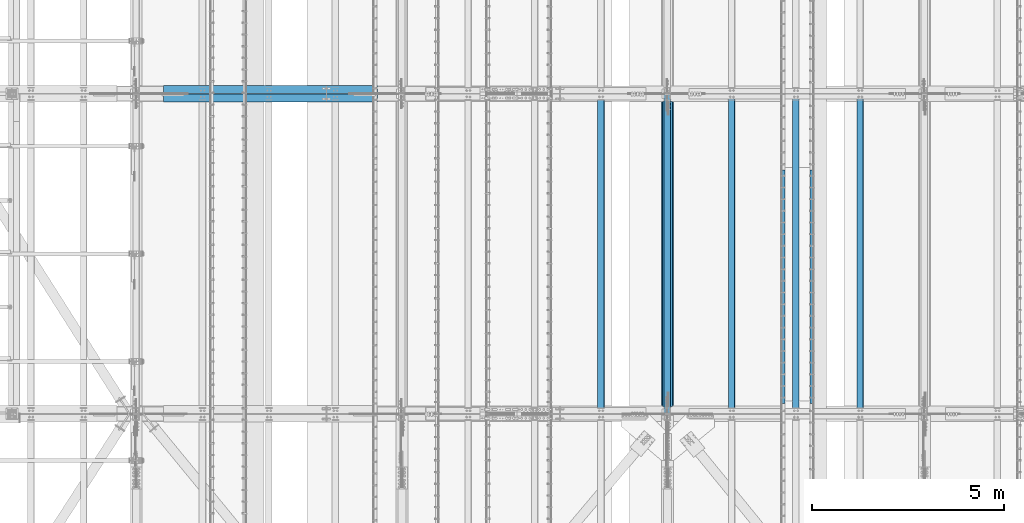
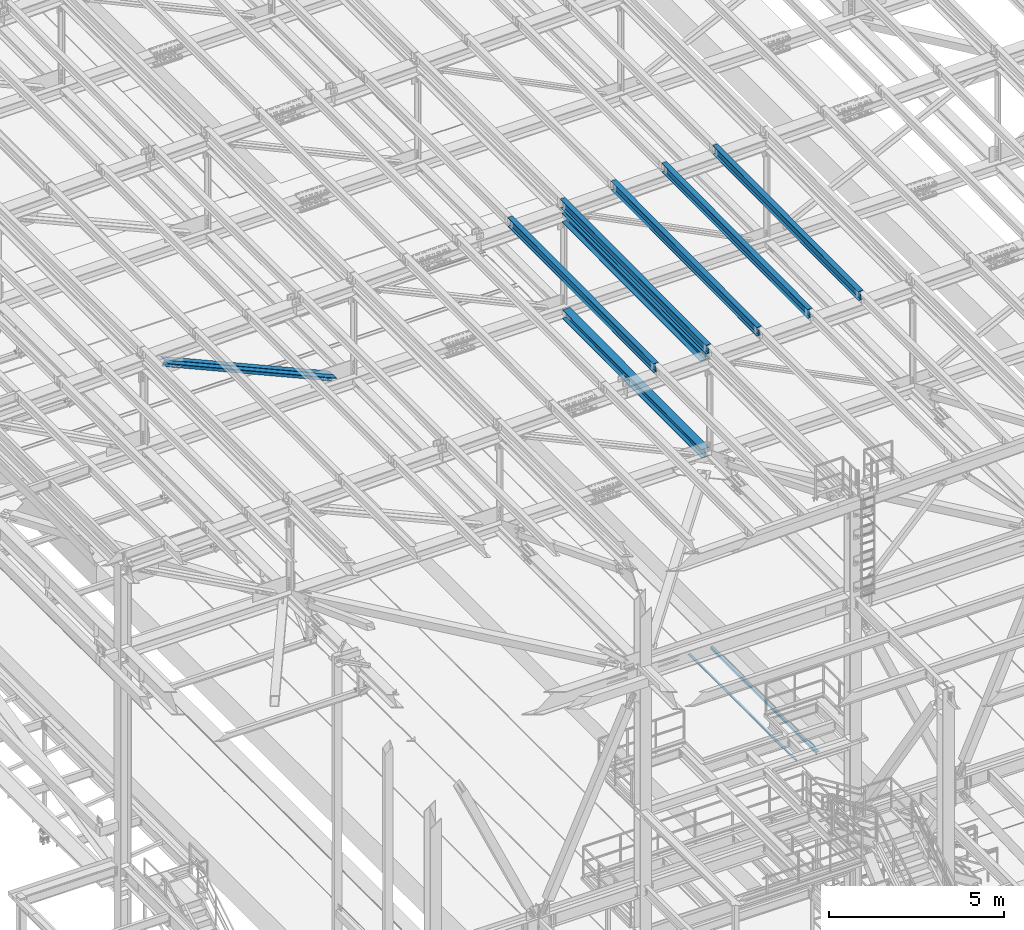
# One storey, part 1826 of 3843: 9 beams, 2 members, 11 elements without a shape of their own.
"""IFC2X3 building model written with IfcOpenShell, lengths in millimetres."""

from ifc_helpers import new_model, si_unit, frame, origin_with_axes, place, context, subcontext, project, spatial, faceted_brep, material, type_object, element, aggregate, save


model = new_model("IFC2X3")

# Units and contexts
model_context = context("Model", 3, precision=1e-05, world=origin_with_axes())
body_context = subcontext(model_context, "Body", "Model", "MODEL_VIEW")
ifc_project = project(units=[si_unit("LENGTHUNIT", "METRE", prefix="MILLI"), si_unit("AREAUNIT", "SQUARE_METRE"), si_unit("VOLUMEUNIT", "CUBIC_METRE"), si_unit("MASSUNIT", "GRAM", prefix="KILO"), si_unit("TIMEUNIT", "SECOND"), si_unit("PLANEANGLEUNIT", "RADIAN"), si_unit("SOLIDANGLEUNIT", "STERADIAN"), si_unit("THERMODYNAMICTEMPERATUREUNIT", "DEGREE_CELSIUS"), si_unit("LUMINOUSINTENSITYUNIT", "LUMEN")], contexts=[model_context])

# Site, building, storey
site_placement = place(None, origin_with_axes())
site = spatial("IfcSite", under=ifc_project, at=site_placement, CompositionType="ELEMENT")
building_placement = place(site_placement, origin_with_axes())
building = spatial("IfcBuilding", under=site, at=building_placement, Name="Undefined", CompositionType="ELEMENT")
storey_placement = place(building_placement, origin_with_axes())
storey = spatial("IfcBuildingStorey", under=building, at=storey_placement, Name="Undefined", CompositionType="ELEMENT", Elevation=0.0)

# Assembly, beam
assembly_1_placement = place(storey_placement, origin_with_axes())
assembly_1 = element("IfcElementAssembly", 1, at=assembly_1_placement, inside=storey, Name="EMBED_ANGLE", AssemblyPlace="NOTDEFINED", PredefinedType="RIGID_FRAME")
ifc_material_1 = material(Name="STEEL/A36")
beam_type_1 = type_object("IfcBeamType", Name="L3-1/2X3-1/2X5/16", PredefinedType="NOTDEFINED")
beam_1_placement = place(assembly_1_placement, frame((59697.1121396484, 40208.072265625, 30410.15), z_axis=(0.0, 0.0, -1.0), x_axis=(0.0, -1.0, 0.0)))
beam_1 = element("IfcBeam", 2, at=beam_1_placement, type_object=beam_type_1, material=ifc_material_1, Name="EMBED_ANGLE", ObjectType="L3-1/2X3-1/2X5/16", context=body_context, shape_type="Brep", body=[
    faceted_brep([(-3.63797880709171e-12, 44.4499999999971, -44.4500000000007), (-3.63797880709171e-12, 44.4499999999971, 44.4500000000007), (6096.0, 44.4499999999971, 44.4500000000007), (6096.0, 44.4499999999971, -44.4500000000007), (-3.63797880709171e-12, 36.5124999999971, 44.4500000000007), (6096.0, 36.5124999999971, 44.4500000000007), (-3.63797880709171e-12, 36.5124999999971, -36.5125000000007), (6096.0, 36.5124999999971, -36.5125000000007), (3.63797880709171e-12, -44.4499999999971, -36.5125000000007), (6096.0, -44.4499999999971, -36.5125000000007), (3.63797880709171e-12, -44.4499999999971, -44.4500000000007), (6096.0, -44.4499999999971, -44.4500000000007)], [[[0, 1, 2, 3]], [[1, 4, 5, 2]], [[4, 6, 7, 5]], [[6, 8, 9, 7]], [[8, 10, 11, 9]], [[10, 0, 3, 11]], [[5, 7, 9, 11, 3, 2]], [[10, 8, 6, 4, 1, 0]]]),
])
aggregate(assembly_1, [beam_1])

assembly_2_placement = place(storey_placement, origin_with_axes())
assembly_2 = element("IfcElementAssembly", 3, at=assembly_2_placement, inside=storey, Name="EMBED_ANGLE", AssemblyPlace="NOTDEFINED", PredefinedType="RIGID_FRAME")
beam_2_placement = place(assembly_2_placement, frame((58947.8753603516, 34112.072265625, 30410.15), z_axis=(0.0, 0.0, -1.0), x_axis=(0.0, 1.0, 0.0)))
beam_2 = element("IfcBeam", 4, at=beam_2_placement, type_object=beam_type_1, material=ifc_material_1, Name="EMBED_ANGLE", ObjectType="L3-1/2X3-1/2X5/16", context=body_context, shape_type="Brep", body=[
    faceted_brep([(-3.63797880709171e-12, 44.4499999999971, -44.4500000000007), (-3.63797880709171e-12, 44.4499999999971, 44.4500000000007), (6096.0, 44.4499999999971, 44.4500000000007), (6096.0, 44.4499999999971, -44.4500000000007), (-3.63797880709171e-12, 36.5124999999971, 44.4500000000007), (6096.0, 36.5124999999971, 44.4500000000007), (-3.63797880709171e-12, 36.5124999999971, -36.5125000000007), (6096.0, 36.5124999999971, -36.5125000000007), (3.63797880709171e-12, -44.4499999999971, -36.5125000000007), (6096.0, -44.4499999999971, -36.5125000000007), (3.63797880709171e-12, -44.4499999999971, -44.4500000000007), (6096.0, -44.4499999999971, -44.4500000000007)], [[[0, 1, 2, 3]], [[1, 4, 5, 2]], [[4, 6, 7, 5]], [[6, 8, 9, 7]], [[8, 10, 11, 9]], [[10, 0, 3, 11]], [[5, 7, 9, 11, 3, 2]], [[10, 8, 6, 4, 1, 0]]]),
])
aggregate(assembly_2, [beam_2])

assembly_3_placement = place(storey_placement, origin_with_axes())
assembly_3 = element("IfcElementAssembly", 5, at=assembly_3_placement, inside=storey, Name="BEAM", AssemblyPlace="NOTDEFINED", PredefinedType="RIGID_FRAME")
ifc_material_2 = material(Name="STEEL/A992")
beam_type_2 = type_object("IfcBeamType", Name="W12X26", PredefinedType="NOTDEFINED")
beam_3_placement = place(assembly_3_placement, frame((55927.5092623517, 33844.3795336606, 45992.7357642946), z_axis=(-0.0211520978450862, -0.00720209800074371, 0.999750328102542), x_axis=(0.0, 0.999974058066208, 0.00720299900047734)))
beam_3 = element("IfcBeam", 6, at=beam_3_placement, type_object=beam_type_2, material=ifc_material_2, Name="BEAM", ObjectType="W12X26", context=body_context, shape_type="Brep", body=[
    faceted_brep([(12.6877508227481, 82.5500000000175, -155.575000000128), (12.7563525796286, 82.5500000000102, -146.050000000127), (8344.17252825745, 82.5500000000466, -146.050000001946), (8344.10392650057, 82.5500000000611, -155.575000001954), (12.7684475449423, 3.17500000014843, -146.050000000068), (8344.18462322276, 3.17500000018481, -146.050000001895), (14.8722347558869, 3.17499999983556, 146.050000000068), (8346.28841043371, 3.17499999987194, 146.049999998249), (14.8601397905804, 82.54999999969, 146.05000000001), (8346.2763154684, 82.5499999997264, 146.049999998191), (14.9287415474537, 82.5499999996828, 155.575000000019), (8346.34491722528, 82.5499999997191, 155.574999998193), (14.9538990753063, -82.5500000000247, 155.575000000135), (8346.37007475313, -82.5499999999884, 155.574999998309), (14.885297318433, -82.5500000000175, 146.050000000127), (8346.30147299625, -82.5499999999738, 146.0499999983), (14.8732023531193, -3.17500000015571, 146.050000000076), (8346.28937803094, -3.17500000011933, 146.049999998249), (12.7694151421674, -3.17499999985012, -146.050000000068), (8344.18559081999, -3.17499999981374, -146.050000001887), (12.7815101074812, -82.5499999997046, -146.05000000001), (8344.19768578529, -82.5499999996682, -146.050000001829), (12.7129083506006, -82.54999999969, -155.575000000019), (8344.12908402842, -82.5499999996537, -155.575000001838)], [[[0, 1, 2, 3]], [[1, 4, 5, 2]], [[4, 6, 7, 5]], [[6, 8, 9, 7]], [[8, 10, 11, 9]], [[10, 12, 13, 11]], [[12, 14, 15, 13]], [[14, 16, 17, 15]], [[16, 18, 19, 17]], [[18, 20, 21, 19]], [[20, 22, 23, 21]], [[22, 0, 3, 23]], [[5, 7, 9, 11, 13, 15, 17, 19, 21, 23, 3, 2]], [[22, 20, 18, 16, 14, 12, 10, 8, 6, 4, 1, 0]]]),
])
aggregate(assembly_3, [beam_3])

assembly_4_placement = place(storey_placement, origin_with_axes())
assembly_4 = element("IfcElementAssembly", 7, at=assembly_4_placement, inside=storey, Name="BEAM", AssemblyPlace="NOTDEFINED", PredefinedType="RIGID_FRAME")
beam_4_placement = place(assembly_4_placement, frame((60956.7092622837, 33844.2819316476, 46101.5634717325), z_axis=(-0.0211520976276079, -0.00782946099840774, 0.999745611796534), x_axis=(0.0, 0.999969335581347, 0.00783121299672119)))
beam_4 = element("IfcBeam", 8, at=beam_4_placement, type_object=beam_type_2, material=ifc_material_2, Name="BEAM", ObjectType="W12X26", context=body_context, shape_type="Brep", body=[
    faceted_brep([(12.6867343784324, 82.5500000001048, -155.575000000143), (12.7612927770024, 82.5500000001048, -146.050000000418), (8344.21677196852, 82.5499999996973, -146.04999998118), (8344.14219406638, 82.5499999997191, -155.574999981211), (12.7744413780092, 3.17500000025029, -146.050000000432), (8344.22992056952, 3.17499999985012, -146.049999981202), (15.0614970436509, 3.17499999971187, 146.05000000049), (8346.51697623517, 3.17499999931169, 146.050000019721), (15.0483484426513, 82.5499999995591, 146.050000000505), (8346.50382763417, 82.5499999991589, 146.050000019743), (15.1229263447894, 82.5499999995518, 155.575000000536), (8346.5784055363, 82.5499999991516, 155.575000019766), (15.1502754348767, -82.5500000001412, 155.575000000499), (8346.6057546264, -82.5500000005413, 155.575000019737), (15.0756975327386, -82.5500000001266, 146.050000000469), (8346.53117672426, -82.5500000005268, 146.050000019706), (15.0625489317317, -3.17500000027212, 146.05000000049), (8346.51802812325, -3.1750000006723, 146.050000019721), (12.7754932660901, -3.1749999997337, -146.050000000439), (8344.23097245761, -3.17500000014115, -146.049999981202), (12.7886418670896, -82.5499999995809, -146.050000000454), (8344.24412105861, -82.5499999999811, -146.049999981216), (12.7140420397991, -82.5500000007742, -155.575000000572), (8344.16954315647, -82.5499999999738, -155.57499998124)], [[[0, 1, 2, 3]], [[1, 4, 5, 2]], [[4, 6, 7, 5]], [[6, 8, 9, 7]], [[8, 10, 11, 9]], [[10, 12, 13, 11]], [[12, 14, 15, 13]], [[14, 16, 17, 15]], [[16, 18, 19, 17]], [[18, 20, 21, 19]], [[20, 22, 23, 21]], [[22, 0, 3, 23]], [[5, 7, 9, 11, 13, 15, 17, 19, 21, 23, 3, 2]], [[22, 20, 18, 16, 14, 12, 10, 8, 6, 4, 1, 0]]]),
])
aggregate(assembly_4, [beam_4])

assembly_5_placement = place(storey_placement, origin_with_axes())
assembly_5 = element("IfcElementAssembly", 9, at=assembly_5_placement, inside=storey, Name="BEAM", AssemblyPlace="NOTDEFINED", PredefinedType="RIGID_FRAME")
beam_5_placement = place(assembly_5_placement, frame((59280.3092622851, 33844.3058569188, 46065.2875102022), z_axis=(-0.0211520983938898, -0.00767567500245056, 0.99974680431937), x_axis=(0.0, 0.999970528391728, 0.00767739200300791)))
beam_5 = element("IfcBeam", 10, at=beam_5_placement, type_object=beam_type_2, material=ifc_material_2, Name="BEAM", ObjectType="W12X26", context=body_context, shape_type="Brep", body=[
    faceted_brep([(12.6869684146077, 82.5499999996318, -155.574999999379), (12.7600813673635, 82.5499999996391, -146.049999999414), (8344.2056224663, 82.5500000000029, -146.050000016847), (8344.13250951354, 82.5499999999956, -155.575000016812), (12.7729716874237, 3.17499999977008, -146.049999999552), (8344.21851278636, 3.17500000013388, -146.050000016985), (15.01510223886, 3.17500000019936, 146.049999999479), (8346.46064333781, 3.17500000056316, 146.049999982053), (15.0022119188143, 82.5500000000684, 146.049999999617), (8346.44775301775, 82.5500000004322, 146.049999982177), (15.07532487157, 82.5500000000829, 155.574999999582), (8346.52086597052, 82.5500000004467, 155.574999982149), (15.1021367372814, -82.5499999996391, 155.574999999306), (8346.54767783623, -82.5499999992753, 155.574999981865), (15.0290237845256, -82.5499999996537, 146.049999999334), (8346.47456488347, -82.5499999992899, 146.049999981893), (15.0161334644654, -3.17499999979191, 146.049999999472), (8346.46167456341, -3.17499999942811, 146.049999982031), (12.7740029130291, -3.17500000022119, -146.049999999559), (8344.21954401197, -3.17499999985012, -146.050000017), (12.7868932330748, -82.5500000000757, -146.049999999697), (8344.23243433201, -82.5499999997119, -146.050000017131), (12.713780280319, -82.5500000000975, -155.574999999662), (8344.15932137926, -82.5499999997337, -155.575000017096)], [[[0, 1, 2, 3]], [[1, 4, 5, 2]], [[4, 6, 7, 5]], [[6, 8, 9, 7]], [[8, 10, 11, 9]], [[10, 12, 13, 11]], [[12, 14, 15, 13]], [[14, 16, 17, 15]], [[16, 18, 19, 17]], [[18, 20, 21, 19]], [[20, 22, 23, 21]], [[22, 0, 3, 23]], [[5, 7, 9, 11, 13, 15, 17, 19, 21, 23, 3, 2]], [[22, 20, 18, 16, 14, 12, 10, 8, 6, 4, 1, 0]]]),
])
aggregate(assembly_5, [beam_5])

assembly_6_placement = place(storey_placement, origin_with_axes())
assembly_6 = element("IfcElementAssembly", 11, at=assembly_6_placement, inside=storey, Name="BEAM", AssemblyPlace="NOTDEFINED", PredefinedType="RIGID_FRAME")
beam_6_placement = place(assembly_6_placement, frame((57603.9092622833, 33844.3383908306, 46029.0116095221), z_axis=(-0.0211520978910194, -0.00746655400006421, 0.999748388008789), x_axis=(0.0, 0.999972112418793, 0.00746822500312756)))
beam_6 = element("IfcBeam", 12, at=beam_6_placement, type_object=beam_type_2, material=ifc_material_2, Name="BEAM", ObjectType="W12X26", context=body_context, shape_type="Brep", body=[
    faceted_brep([(12.6873135183923, 82.5499999997119, -155.575000000048), (12.7584344299103, 82.5499999997191, -146.050000000047), (8344.19077792334, 82.5499999993626, -146.049999983261), (8344.11965701182, 82.5499999993554, -155.574999983277), (12.7709735392637, 3.17499999986467, -146.050000000192), (8344.20331703269, 3.17499999950815, -146.049999983406), (14.9520148258089, 3.1750000001266, 146.050000000258), (8346.38435831924, 3.17499999977008, 146.050000017043), (14.9394757164628, 82.5499999999738, 146.05000000041), (8346.37181920989, 82.5499999996173, 146.050000017196), (15.0105966279807, 82.5499999999811, 155.575000000419), (8346.44294012141, 82.5499999996246, 155.575000017205), (15.0366779754331, -82.5499999997119, 155.575000000106), (8346.46902146885, -82.5500000000684, 155.575000016892), (14.9655570639079, -82.5499999997191, 146.05000000009), (8346.39790055734, -82.5500000000757, 146.050000016876), (14.9530179545618, -3.17499999987194, 146.050000000236), (8346.38536144799, -3.17500000022847, 146.050000017021), (12.7719766680166, -3.1750000001266, -146.050000000207), (8344.20432016144, -3.17500000048312, -146.049999983421), (12.7845157773627, -82.5499999999738, -146.050000000359), (8344.21685927079, -82.5500000003303, -146.049999983574), (12.713394865852, -82.5499999999811, -155.575000000368), (8344.14573835927, -82.5500000003376, -155.574999983583)], [[[0, 1, 2, 3]], [[1, 4, 5, 2]], [[4, 6, 7, 5]], [[6, 8, 9, 7]], [[8, 10, 11, 9]], [[10, 12, 13, 11]], [[12, 14, 15, 13]], [[14, 16, 17, 15]], [[16, 18, 19, 17]], [[18, 20, 21, 19]], [[20, 22, 23, 21]], [[22, 0, 3, 23]], [[5, 7, 9, 11, 13, 15, 17, 19, 21, 23, 3, 2]], [[22, 20, 18, 16, 14, 12, 10, 8, 6, 4, 1, 0]]]),
])
aggregate(assembly_6, [beam_6])

assembly_7_placement = place(storey_placement, origin_with_axes())
assembly_7 = element("IfcElementAssembly", 13, at=assembly_7_placement, inside=storey, Name="BEAM", AssemblyPlace="NOTDEFINED", PredefinedType="RIGID_FRAME")
beam_7_placement = place(assembly_7_placement, frame((54193.9592622851, 33844.4317702754, 45955.2232979371), z_axis=(-0.0211520978615081, -0.00686633299678943, 0.999752690532631), x_axis=(0.0, 0.999976415909599, 0.00686786899937917)))
beam_7 = element("IfcBeam", 14, at=beam_7_placement, type_object=beam_type_2, material=ifc_material_2, Name="BEAM", ObjectType="W12X26", context=body_context, shape_type="Brep", body=[
    faceted_brep([(12.6883072716955, 82.5500000003958, -155.575000000463), (12.7537106307136, 82.5500000003667, -146.050000000447), (8344.15019900299, 82.5500000001775, -146.049999991686), (8344.08479564398, 82.5500000002139, -155.574999991702), (12.765241695779, 3.1750000005195, -146.050000000243), (8344.16173006805, 3.1750000003376, -146.049999991483), (14.7709447056477, 3.17499999946449, 146.050000000236), (8346.16743307792, 3.17499999928259, 146.050000009003), (14.7594136405824, 82.5499999993117, 146.050000000032), (8346.15590201286, 82.5499999991298, 146.0500000088), (14.8248169996004, 82.5499999992753, 155.575000000048), (8346.22130537188, 82.5499999990934, 155.575000008808), (14.8488016149422, -82.5500000003958, 155.575000000477), (8346.24528998721, -82.5500000005777, 155.575000009238), (14.7833982559241, -82.5500000003667, 146.050000000454), (8346.1798866282, -82.5500000005486, 146.050000009214), (14.7718671908515, -3.1750000005195, 146.050000000258), (8346.16835556314, -3.1750000007014, 146.050000009011), (12.7661641809827, -3.17499999946449, -146.050000000221), (8344.16265255326, -3.17499999965366, -146.049999991461), (12.7776952460481, -82.5499999993117, -146.050000000017), (8344.17418361832, -82.5499999995009, -146.049999991257), (12.71229188703, -82.5499999992753, -155.575000000033), (8344.10878025931, -82.5499999994645, -155.574999991273)], [[[0, 1, 2, 3]], [[1, 4, 5, 2]], [[4, 6, 7, 5]], [[6, 8, 9, 7]], [[8, 10, 11, 9]], [[10, 12, 13, 11]], [[12, 14, 15, 13]], [[14, 16, 17, 15]], [[16, 18, 19, 17]], [[18, 20, 21, 19]], [[20, 22, 23, 21]], [[22, 0, 3, 23]], [[5, 7, 9, 11, 13, 15, 17, 19, 21, 23, 3, 2]], [[22, 20, 18, 16, 14, 12, 10, 8, 6, 4, 1, 0]]]),
])
aggregate(assembly_7, [beam_7])

# Assembly, member
assembly_8_placement = place(storey_placement, origin_with_axes())
assembly_8 = element("IfcElementAssembly", 15, at=assembly_8_placement, inside=storey, Name="ANGLE", AssemblyPlace="NOTDEFINED", PredefinedType="RIGID_FRAME")
ifc_material_3 = material(Name="STEEL/A572-50")
member_type = type_object("IfcMemberType", Name="L8X8X1/2", PredefinedType="NOTDEFINED")
member_1_placement = place(assembly_8_placement, frame((42062.4, 42313.225, 45363.6585973172), z_axis=(-0.404302056875182, 0.0, -0.91462552271763), x_axis=(0.91462552271763, 0.0, -0.404302056875181)))
member_1 = element("IfcMember", 16, at=member_1_placement, type_object=member_type, material=ifc_material_3, Name="ANGLE", ObjectType="L8X8X1/2", context=body_context, shape_type="Brep", body=[
    faceted_brep([(739.581360490989, 101.599999999999, -101.599999997437), (739.581360490993, 101.599999999999, 101.600000002734), (6835.80295340148, 101.599999999999, 101.600000024591), (6835.80295340147, 101.599999999999, -101.59999997558), (739.581360490993, 88.9000000000015, 101.600000002734), (6835.80295340148, 88.9000000000015, 101.600000024591), (739.581360490993, 88.9000000000015, -88.8999999974258), (6835.80295340147, 88.9000000000015, -88.8999999755615), (739.581360490993, -101.599999999999, -88.8999999974258), (6835.80295340147, -101.599999999999, -88.8999999755615), (739.581360490989, -101.599999999999, -101.599999997437), (6835.80295340147, -101.599999999999, -101.59999997558)], [[[0, 1, 2, 3]], [[1, 4, 5, 2]], [[4, 6, 7, 5]], [[6, 8, 9, 7]], [[8, 10, 11, 9]], [[10, 0, 3, 11]], [[5, 7, 9, 11, 3, 2]], [[10, 8, 6, 4, 1, 0]]]),
])
aggregate(assembly_8, [member_1])

assembly_9_placement = place(storey_placement, origin_with_axes())
assembly_9 = element("IfcElementAssembly", 17, at=assembly_9_placement, inside=storey, Name="ANGLE", AssemblyPlace="NOTDEFINED", PredefinedType="RIGID_FRAME")
member_2_placement = place(assembly_9_placement, frame((48996.6, 42090.975, 42298.4573158048), z_axis=(-0.404302056875182, 0.0, -0.91462552271763), x_axis=(-0.914625522717631, 0.0, 0.404302056875179)))
member_2 = element("IfcMember", 18, at=member_2_placement, type_object=member_type, material=ifc_material_3, Name="ANGLE", ObjectType="L8X8X1/2", context=body_context, shape_type="Brep", body=[
    faceted_brep([(745.660529091951, 101.599999999999, -101.600000002756), (745.660529091958, 101.599999999999, 101.599999997401), (6841.88212200243, 101.599999999999, 101.599999975544), (6841.88212200243, 101.599999999999, -101.600000024628), (745.660529091958, 88.9000000000015, 101.599999997401), (6841.88212200243, 88.9000000000015, 101.599999975544), (745.660529091958, 88.9000000000015, -88.900000002759), (6841.88212200244, 88.9000000000015, -88.900000024616), (745.660529091958, -101.599999999999, -88.900000002759), (6841.88212200244, -101.599999999999, -88.900000024616), (745.660529091951, -101.599999999999, -101.600000002756), (6841.88212200243, -101.599999999999, -101.600000024628)], [[[0, 1, 2, 3]], [[1, 4, 5, 2]], [[4, 6, 7, 5]], [[6, 8, 9, 7]], [[8, 10, 11, 9]], [[10, 0, 3, 11]], [[5, 7, 9, 11, 3, 2]], [[10, 8, 6, 4, 1, 0]]]),
])
aggregate(assembly_9, [member_2])

# Assembly, beam
assembly_10_placement = place(storey_placement, origin_with_axes())
assembly_10 = element("IfcElementAssembly", 19, at=assembly_10_placement, inside=storey, Name="BEAM", AssemblyPlace="NOTDEFINED", PredefinedType="RIGID_FRAME")
beam_type_3 = type_object("IfcBeamType", Name="W12X65", PredefinedType="NOTDEFINED")
beam_8_placement = place(assembly_10_placement, frame((55930.8, 33845.5, 45640.3035239101), z_axis=(0.0, -0.00720299900047391, 0.999974058066208), x_axis=(0.0, 0.999974058066208, 0.00720299900047734)))
beam_8 = element("IfcBeam", 20, at=beam_8_placement, type_object=beam_type_3, material=ifc_material_2, Name="BEAM", ObjectType="W12X65", context=body_context, shape_type="Brep", body=[
    faceted_brep([(211.621318058344, 152.400000000001, -153.987500001), (211.735668633955, 152.400000000001, -138.112500000978), (8143.09142336596, 152.400000000001, -138.112500029085), (8142.97707279035, 152.400000000001, -153.987500029114), (211.735668633955, 4.76249999999709, -138.112500000978), (8143.09142336596, 4.76249999999709, -138.112500029085), (213.725368649531, 4.76249999999709, 138.112499999479), (8145.08112338153, 4.76249999999709, 138.112499971365), (213.725368649531, 152.400000000001, 138.112499999479), (8145.08112338153, 152.400000000001, 138.112499971365), (213.839719225136, 152.400000000001, 153.987499999501), (8145.19547395714, 152.400000000001, 153.987499971394), (213.839719225136, -152.400000000001, 153.987499999501), (8145.19547395714, -152.400000000001, 153.987499971394), (213.725368649531, -152.400000000001, 138.112499999479), (8145.08112338153, -152.400000000001, 138.112499971365), (213.725368649531, -4.76249999999709, 138.112499999479), (8145.08112338153, -4.76249999999709, 138.112499971365), (211.735668633955, -4.76249999999709, -138.112500000978), (8143.09142336596, -4.76249999999709, -138.112500029085), (211.735668633955, -152.400000000001, -138.112500000978), (8143.09142336596, -152.400000000001, -138.112500029085), (211.621318058344, -152.400000000001, -153.987500001), (8142.97707279035, -152.400000000001, -153.987500029114)], [[[0, 1, 2, 3]], [[1, 4, 5, 2]], [[4, 6, 7, 5]], [[6, 8, 9, 7]], [[8, 10, 11, 9]], [[10, 12, 13, 11]], [[12, 14, 15, 13]], [[14, 16, 17, 15]], [[16, 18, 19, 17]], [[18, 20, 21, 19]], [[20, 22, 23, 21]], [[22, 0, 3, 23]], [[5, 7, 9, 11, 13, 15, 17, 19, 21, 23, 3, 2]], [[22, 20, 18, 16, 14, 12, 10, 8, 6, 4, 1, 0]]]),
])
aggregate(assembly_10, [beam_8])

assembly_11_placement = place(storey_placement, origin_with_axes())
assembly_11 = element("IfcElementAssembly", 21, at=assembly_11_placement, inside=storey, Name="BEAM", AssemblyPlace="NOTDEFINED", PredefinedType="RIGID_FRAME")
beam_type_4 = type_object("IfcBeamType", Name="W12X53", PredefinedType="NOTDEFINED")
beam_9_placement = place(assembly_11_placement, frame((55930.8, 33845.5, 42255.8947888465), z_axis=(0.0, -0.00720180099780552, 0.999974066694926), x_axis=(0.0, 0.999974066694926, 0.00720180099780243)))
beam_9 = element("IfcBeam", 22, at=beam_9_placement, type_object=beam_type_4, material=ifc_material_2, Name="BEAM", ObjectType="W12X53", context=body_context, shape_type="Brep", body=[
    faceted_brep([(197.345063338566, 127.0, -152.4000000007), (197.447961738821, 127.0, -138.112500000672), (8157.37938910443, 127.0, -138.11250001537), (8157.27649070417, 127.0, -152.400000015397), (197.447961738821, 4.76249999999709, -138.112500000672), (8157.37938910443, 4.76249999999709, -138.11250001537), (199.43733081036, 4.76249999999709, 138.112499999945), (8159.36875817596, 4.76249999999709, 138.112499985247), (199.43733081036, 127.0, 138.112499999945), (8159.36875817596, 127.0, 138.112499985247), (199.540229210608, 127.0, 152.39999999998), (8159.47165657621, 127.0, 152.399999985282), (199.540229210608, -127.0, 152.39999999998), (8159.47165657621, -127.0, 152.399999985282), (199.43733081036, -127.0, 138.112499999945), (8159.36875817596, -127.0, 138.112499985247), (199.43733081036, -4.76249999999709, 138.112499999945), (8159.36875817596, -4.76249999999709, 138.112499985247), (197.447961738821, -4.76249999999709, -138.112500000672), (8157.37938910443, -4.76249999999709, -138.11250001537), (197.447961738821, -127.0, -138.112500000672), (8157.37938910443, -127.0, -138.11250001537), (197.345063338566, -127.0, -152.4000000007), (8157.27649070417, -127.0, -152.400000015397)], [[[0, 1, 2, 3]], [[1, 4, 5, 2]], [[4, 6, 7, 5]], [[6, 8, 9, 7]], [[8, 10, 11, 9]], [[10, 12, 13, 11]], [[12, 14, 15, 13]], [[14, 16, 17, 15]], [[16, 18, 19, 17]], [[18, 20, 21, 19]], [[20, 22, 23, 21]], [[22, 0, 3, 23]], [[5, 7, 9, 11, 13, 15, 17, 19, 21, 23, 3, 2]], [[22, 20, 18, 16, 14, 12, 10, 8, 6, 4, 1, 0]]]),
])
aggregate(assembly_11, [beam_9])

save(model, "model.ifc")
